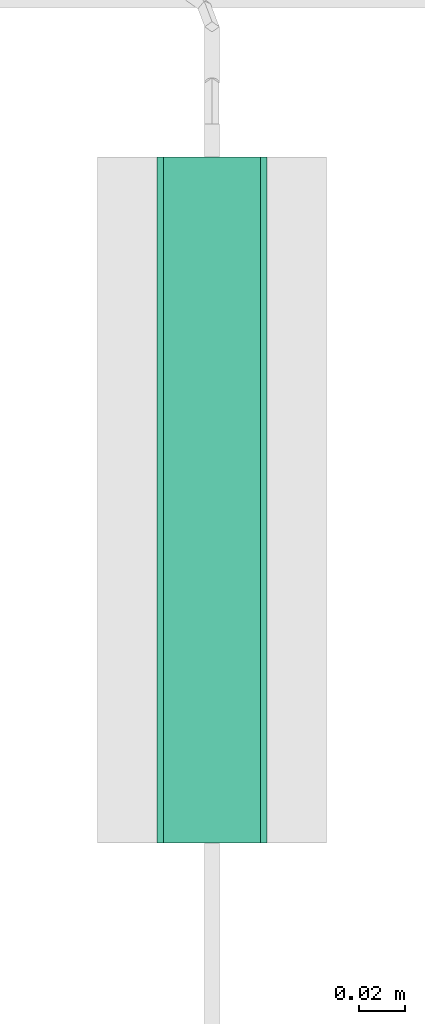
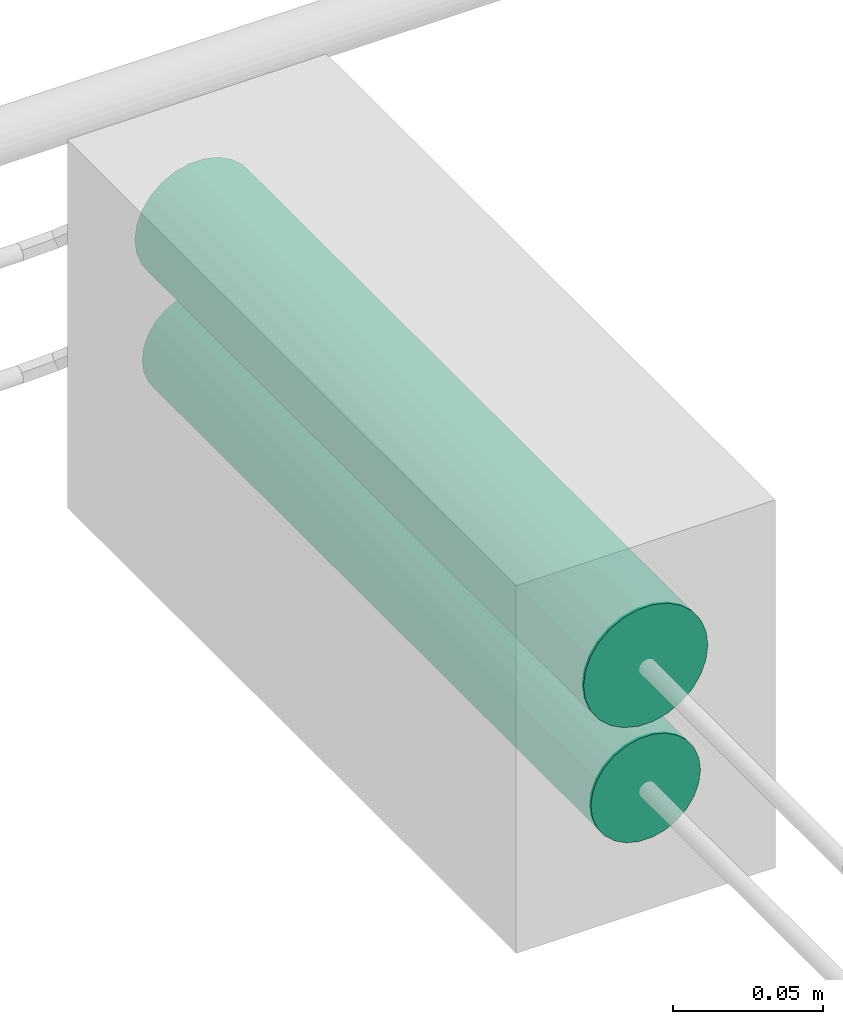
# One storey, part 27 of 45: 2 flow segments.
"""IFC2X3 building model written with IfcOpenShell, lengths in millimetres."""

from ifc_helpers import new_model, entity, si_unit, converted_unit, derived_unit, direction, frame, origin, origin_2d_with_axis, place, context, subcontext, project, spatial, circle, extrude, type_object, element, save


model = new_model("IFC2X3")

# Units and contexts
model_context = context("Model", 3, precision=0.01, world=origin(), true_north=direction((6.12303176911189e-17, 1.0)))
body_context = subcontext(model_context, "Body", "Model", "MODEL_VIEW")
ifc_project = project(units=[si_unit("LENGTHUNIT", "METRE", prefix="MILLI"), si_unit("AREAUNIT", "SQUARE_METRE"), si_unit("VOLUMEUNIT", "CUBIC_METRE"), converted_unit("PLANEANGLEUNIT", "DEGREE", entity("IfcRatioMeasure", 0.0174532925199433), si_unit("PLANEANGLEUNIT", "RADIAN"), dimensions=[0, 0, 0, 0, 0, 0, 0]), si_unit("MASSUNIT", "GRAM", prefix="KILO"), derived_unit("MASSDENSITYUNIT", [(si_unit("MASSUNIT", "GRAM", prefix="KILO"), 1), (si_unit("LENGTHUNIT", "METRE"), -3)]), derived_unit("MOMENTOFINERTIAUNIT", [(si_unit("LENGTHUNIT", "METRE"), 4)]), si_unit("TIMEUNIT", "SECOND"), si_unit("FREQUENCYUNIT", "HERTZ"), si_unit("THERMODYNAMICTEMPERATUREUNIT", "DEGREE_CELSIUS"), derived_unit("THERMALTRANSMITTANCEUNIT", [(si_unit("MASSUNIT", "GRAM", prefix="KILO"), 1), (si_unit("THERMODYNAMICTEMPERATUREUNIT", "KELVIN"), -1), (si_unit("TIMEUNIT", "SECOND"), -3)]), derived_unit("VOLUMETRICFLOWRATEUNIT", [(si_unit("LENGTHUNIT", "METRE"), 3), (si_unit("TIMEUNIT", "SECOND"), -1)]), derived_unit("MASSFLOWRATEUNIT", [(si_unit("MASSUNIT", "GRAM", prefix="KILO"), 1), (si_unit("TIMEUNIT", "SECOND"), -1)]), derived_unit("ROTATIONALFREQUENCYUNIT", [(si_unit("TIMEUNIT", "SECOND"), -1)]), si_unit("ELECTRICCURRENTUNIT", "AMPERE"), si_unit("ELECTRICVOLTAGEUNIT", "VOLT"), si_unit("POWERUNIT", "WATT"), si_unit("FORCEUNIT", "NEWTON", prefix="KILO"), si_unit("ILLUMINANCEUNIT", "LUX"), si_unit("LUMINOUSFLUXUNIT", "LUMEN"), si_unit("LUMINOUSINTENSITYUNIT", "CANDELA"), derived_unit("USERDEFINED", [(si_unit("MASSUNIT", "GRAM", prefix="KILO"), -1), (si_unit("LENGTHUNIT", "METRE"), -2), (si_unit("TIMEUNIT", "SECOND"), 3), (si_unit("LUMINOUSFLUXUNIT", "LUMEN"), 1)]), derived_unit("LINEARVELOCITYUNIT", [(si_unit("LENGTHUNIT", "METRE"), 1), (si_unit("TIMEUNIT", "SECOND"), -1)]), si_unit("PRESSUREUNIT", "PASCAL"), derived_unit("USERDEFINED", [(si_unit("LENGTHUNIT", "METRE"), -2), (si_unit("MASSUNIT", "GRAM", prefix="KILO"), 1), (si_unit("TIMEUNIT", "SECOND"), -2)]), derived_unit("LINEARFORCEUNIT", [(si_unit("MASSUNIT", "GRAM", prefix="KILO"), 1), (si_unit("LENGTHUNIT", "METRE"), 1), (si_unit("TIMEUNIT", "SECOND"), -2), (si_unit("LENGTHUNIT", "METRE"), -1)]), derived_unit("PLANARFORCEUNIT", [(si_unit("MASSUNIT", "GRAM", prefix="KILO"), 1), (si_unit("LENGTHUNIT", "METRE"), 1), (si_unit("TIMEUNIT", "SECOND"), -2), (si_unit("LENGTHUNIT", "METRE"), -2)])], contexts=[model_context])

# Site, building, storey
site_placement = place(None, frame((-24836.06, 8968.75, 0.0)))
site = spatial("IfcSite", under=ifc_project, at=site_placement, CompositionType="ELEMENT")
building_placement = place(site_placement, origin())
building = spatial("IfcBuilding", under=site, at=building_placement, CompositionType="ELEMENT")
storey_placement = place(building_placement, frame((0.0, 0.0, -4200.0)))
storey = spatial("IfcBuildingStorey", under=building, at=storey_placement, CompositionType="ELEMENT", Elevation=-4200.0)

# Flow segments
pipe_segment_type = type_object("IfcPipeSegmentType", PredefinedType="NOTDEFINED")
flow_segment_1_placement = place(storey_placement, frame((87770.65, -1338.75, 2174.4)))
element("IfcFlowSegment", 1, at=flow_segment_1_placement, inside=storey, type_object=pipe_segment_type, context=body_context, shape_type="SweptSolid", body=[
    extrude(circle(Radius=24.0, at=origin_2d_with_axis()), frame((25.6, 0.0, 25.6), z_axis=(0.0, 1.0, 0.0), x_axis=(1.0, 0.0, 0.0)), (0.0, 0.0, 1.0), 299.999999999999),
])
flow_segment_2_placement = place(storey_placement, frame((87773.5, -1338.75, 2127.25)))
element("IfcFlowSegment", 2, at=flow_segment_2_placement, inside=storey, type_object=pipe_segment_type, context=body_context, shape_type="SweptSolid", body=[
    extrude(circle(Radius=21.15, at=origin_2d_with_axis()), frame((22.75, 0.0, 22.75), z_axis=(0.0, 1.0, 0.0), x_axis=(1.0, 0.0, 0.0)), (0.0, 0.0, 1.0), 300.000000000008),
])

save(model, "model.ifc")
